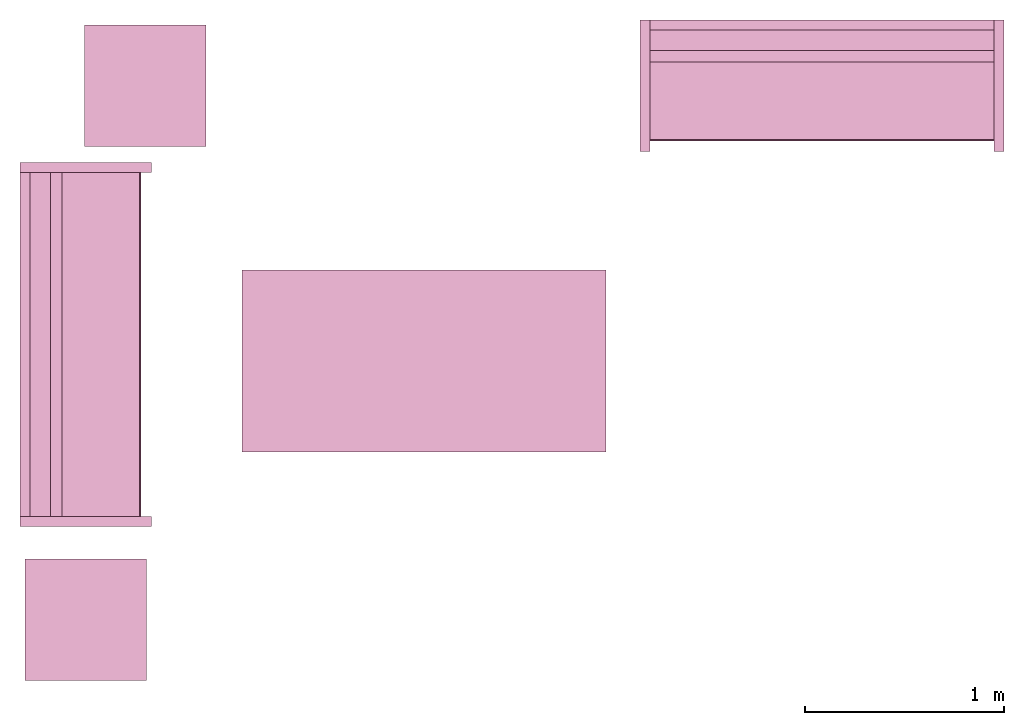
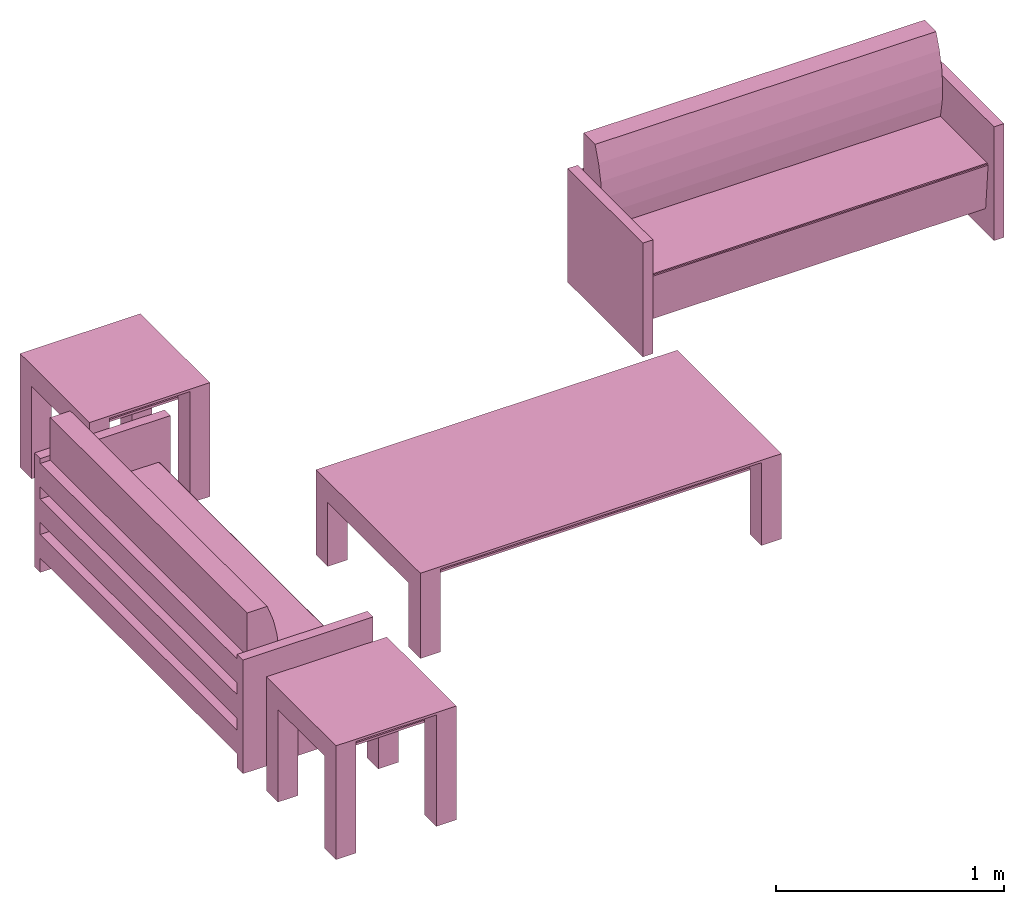
# One storey: 5 furnishings.
"""IFC2X3 building model written with IfcOpenShell, lengths in metres."""

from ifc_helpers import new_model, entity, si_unit, converted_unit, frame, origin, origin_with_axes, origin_2d_with_axis, place, context, project, spatial, polyline, rectangle, outline, extrude, face_set, surface_model, source, transform, mapped, type_object, type_shapes, element, save


model = new_model("IFC2X3")

# Units and contexts
model_context = context("Model", 3, precision=1e-09, world=origin())
plan_context = context("Plan", 3, precision=1e-09, world=origin())
ifc_project = project(units=[si_unit("LENGTHUNIT", "METRE"), si_unit("AREAUNIT", "SQUARE_METRE"), si_unit("VOLUMEUNIT", "CUBIC_METRE"), converted_unit("PLANEANGLEUNIT", "DEGREE", entity("IfcRatioMeasure", 0.0174532925199433), si_unit("PLANEANGLEUNIT", "RADIAN"), dimensions=[0, 0, 0, 0, 0, 0, 0]), si_unit("TIMEUNIT", "SECOND")], contexts=[model_context, plan_context])

# Site, building, storey, space
site_placement = place(None, origin_with_axes())
site = spatial("IfcSite", under=ifc_project, at=site_placement, CompositionType="ELEMENT")
building_placement = place(None, origin_with_axes())
building = spatial("IfcBuilding", under=site, at=building_placement, CompositionType="ELEMENT")
storey_placement = place(None, origin_with_axes())
storey = spatial("IfcBuildingStorey", under=building, at=storey_placement, Name="Level 1", CompositionType="ELEMENT", Elevation=0.0)
space_placement = place(None, origin_with_axes())
space = spatial("IfcSpace", under=storey, at=space_placement, CompositionType="ELEMENT", InteriorOrExteriorSpace="INTERNAL")

# Furnishings
furniture_type_1 = type_object("IfcFurnitureType", Name="0915 x 1830 x 0457mm", AssemblyPlace="NOTDEFINED")
shared_shape_1 = source(origin(), model_context, "Body", "SweptSolid", [
    extrude(rectangle(XDim=1.6268, YDim=0.711799999999999, at=origin_2d_with_axis()), frame((0.0182657666726317, 0.0952110778022268, 0.3427), z_axis=(0.0, 0.0, 1.0), x_axis=(-1.0, 0.0, 0.0)), (0.0, 0.0, 1.0), 0.0127),
    extrude(outline(polyline([(-0.196749999999994, -0.4575), (0.247549999999978, -0.4575), (0.247549999999978, 0.457499999999999), (-0.196749999999993, 0.457499999999999), (-0.196749999999993, 0.355900000000002), (0.145950000000009, 0.355900000000001), (0.145950000000009, -0.3559), (-0.196749999999994, -0.3559), (-0.196749999999994, -0.4575)])), frame((0.831665766672632, 0.0952110778022354, 0.196749999999991), z_axis=(1.0, 0.0, 0.0), x_axis=(0.0, 0.0, 1.0)), (0.0, 0.0, 1.0), 0.1016),
    extrude(outline(polyline([(-0.457500000000004, -0.247550000000026), (0.457499999999994, -0.247550000000026), (0.457499999999994, 0.196750000000011), (0.355900000000004, 0.196750000000011), (0.355900000000004, -0.145949999999996), (-0.355899999999994, -0.145949999999996), (-0.355899999999994, 0.196750000000011), (-0.457500000000004, 0.196750000000011), (-0.457500000000004, -0.247550000000026)])), frame((-0.896734233327367, 0.0952110778022256, 0.196750000000009), z_axis=(1.0, 0.0, 0.0), x_axis=(0.0, -1.0, 0.0)), (0.0, 0.0, 1.0), 0.1016),
    extrude(rectangle(XDim=1.6268, YDim=0.711799999999999, at=origin_2d_with_axis()), frame((0.0182657666726317, 0.0952110778022265, 0.4443), z_axis=(0.0, 0.0, 1.0), x_axis=(-1.0, 0.0, 0.0)), (0.0, 0.0, 1.0), 0.0127),
    extrude(outline(polyline([(-0.915, -0.457500000000023), (0.915, -0.457500000000023), (0.915, 0.457500000000023), (-0.915, 0.457500000000023), (-0.915, -0.457500000000023)]), holes=[polyline([(-0.813399999999998, -0.355899999999975), (-0.813399999999998, 0.355900000000025), (0.813400000000001, 0.355900000000024), (0.813400000000001, -0.355899999999975), (-0.813399999999998, -0.355899999999975)])]), frame((0.0182657666726332, 0.0952110778022514, 0.4443), z_axis=(0.0, 0.0, 1.0), x_axis=(-1.0, 0.0, 0.0)), (0.0, 0.0, 1.0), 0.0127),
])
type_shapes(furniture_type_1, [shared_shape_1])
furnishing_1_placement = place(None, frame((2.61916508073939, -15.3431715869351, 0.0), z_axis=(0.0, 0.0, 1.0), x_axis=(-1.0, 0.0, 0.0)))
element("IfcFurnishingElement", 1, at=furnishing_1_placement, inside=space, type_object=furniture_type_1, Name="M_Table-Coffee:0915 x 1830 x 0457mm:0915 x 1830 x 0457mm", context=model_context, shape_type="MappedRepresentation", body=[
    mapped(shared_shape_1, transform((0.0, 0.0, 0.0), scale=1.0)),
])
furniture_type_2 = type_object("IfcFurnitureType", Name="1830mm", AssemblyPlace="NOTDEFINED")
shared_shape_2 = source(origin(), model_context, "Body", "SurfaceModel", [
    surface_model("IfcFaceBasedSurfaceModel", [(0.0507999999999982, 0.609599999999997, 0.5842), (0.0507999999999983, 0.660399999999998, 0.5842), (0.0507999999999983, 0.660399999999998, 0.4572), (0.0507999999999982, 0.609599999999997, 0.4572), (0.0507999999999982, 0.609599999999998, 0.3937), (0.0507999999999983, 0.660399999999998, 0.3937), (0.0507999999999983, 0.660399999999998, 0.2667), (0.0507999999999982, 0.609599999999998, 0.2667), (0.0507999999999982, 0.609600000000004, 0.2032), (0.0507999999999983, 0.660399999999998, 0.2032), (0.0507999999999983, 0.660399999999998, 0.0762), (0.0507999999999982, 0.609600000000004, 0.0762), (1.77919999999999, 0.609599999999994, 0.5842), (1.77919999999999, 0.609599999999994, 0.4572), (1.77919999999999, 0.660399999999995, 0.4572), (1.77919999999999, 0.660399999999995, 0.5842), (1.77919999999999, 0.609599999999995, 0.3937), (1.77919999999999, 0.609599999999995, 0.2667), (1.77919999999999, 0.660399999999995, 0.2667), (1.77919999999999, 0.660399999999995, 0.3937), (1.77919999999999, 0.609600000000001, 0.2032), (1.77919999999999, 0.609600000000001, 0.0762), (1.77919999999999, 0.660399999999995, 0.0762), (1.77919999999999, 0.660399999999995, 0.2032), (0.0507999999999978, 0.470222395089521, 0.380999999999998), (0.0507999999999978, 0.454401348887885, 0.467831162756508), (0.0507999999999978, 0.450300415835913, 0.555996567971167), (0.0507999999999978, 0.457992845249543, 0.643921438504357), (0.0507999999999978, 0.477341237862486, 0.730035293556011), (0.0507999999999979, 0.507999999999975, 0.812799999999995), (0.0507999999999981, 0.609599999999998, 0.812799999999998), (0.0507999999999981, 0.609599999999998, 0.127966546684697), (0.0507999999999971, 0.0729375586579064, 0.127966546684697), (0.0507999999999971, 0.0520079452978146, 0.367193122067106), (0.0507999999999971, 0.0526336053189921, 0.372382281209352), (0.0507999999999971, 0.0552961957860913, 0.37687999563672), (0.0507999999999971, 0.0595447350023739, 0.379924455784818), (0.0507999999999971, 0.0646596179635799, 0.381000000000001), (1.77919999999998, 0.470222395089517, 0.381000000000001), (1.77919999999998, 0.0646596179635769, 0.381000000000001), (1.77919999999998, 0.059544735002371, 0.379924455784818), (1.77919999999998, 0.0552961957860883, 0.37687999563672), (1.77919999999998, 0.0526336053189891, 0.372382281209352), (1.77919999999998, 0.0520079452978117, 0.367193122067106), (1.77919999999998, 0.0729375586579034, 0.127966546684697), (1.77919999999998, 0.609599999999995, 0.127966546684697), (1.77919999999998, 0.609599999999995, 0.812799999999998), (1.77919999999998, 0.507999999999972, 0.812799999999995), (1.77919999999998, 0.477341237862483, 0.730035293556011), (1.77919999999998, 0.45799284524954, 0.643921438504357), (1.77919999999998, 0.45030041583591, 0.555996567971167), (1.77919999999998, 0.454401348887882, 0.467831162756508), (0.050799984484911, 0.0539648979902268, 0.374631136655807), (1.77919995784759, 0.0539648979902268, 0.374631136655807), (0.050799984484911, 0.0523207746446133, 0.369787722826004), (1.77919995784759, 0.0523207746446133, 0.369787722826004), (1.77919995784759, 0.0621021725237369, 0.380462229251862), (0.050799984484911, 0.0621788389980793, 0.380478352308273), (1.77919995784759, 0.0574204623699188, 0.378402233123779), (0.050799984484911, 0.0574204623699188, 0.378402233123779), (0.0507999999999971, 0.660399999999997, 0.6096), (0.0507999999999971, 0.0, 0.6096), (0.0, 0.0, 0.6096), (0.0, 0.660399999999997, 0.6096), (1.83, 0.660400000000039, 0.6096), (1.83, 0.0, 0.6096), (1.77919999999997, 0.0, 0.6096), (1.77919999999997, 0.660400000000039, 0.6096), (0.0507999999999971, 0.660399999999997, 0.0), (0.0507999999999971, 0.0, 0.0), (0.0, 0.0, 0.0), (0.0, 0.660399999999997, 0.0), (1.83, 0.660400000000039, 0.0), (1.83, 0.0, 0.0), (1.77919999999997, 0.0, 0.0), (1.77919999999997, 0.660400000000039, 0.0)], [face_set([[[0, 1, 2, 3]], [[4, 5, 6, 7]], [[8, 9, 10, 11]], [[12, 13, 14, 15]], [[16, 17, 18, 19]], [[20, 21, 22, 23]], [[1, 15, 12, 0]], [[2, 14, 15, 1]], [[3, 2, 14, 13]], [[0, 3, 13, 12]], [[5, 19, 16, 4]], [[6, 18, 19, 5]], [[7, 6, 18, 17]], [[4, 7, 17, 16]], [[9, 23, 20, 8]], [[10, 22, 23, 9]], [[11, 10, 22, 21]], [[8, 11, 21, 20]]]), face_set([[[24, 25, 26, 27, 28, 29, 30, 31, 32, 33, 34, 35, 36, 37]], [[38, 39, 40, 41, 42, 43, 44, 45, 46, 47, 48, 49, 50, 51]], [[24, 25, 51, 38]], [[25, 26, 50, 51]], [[49, 50, 26, 27]], [[27, 28, 48, 49]], [[28, 29, 47, 48]], [[30, 46, 47, 29]], [[31, 30, 46, 45]], [[32, 31, 45, 44]], [[33, 32, 44, 43]], [[41, 35, 52, 53]], [[54, 55, 42, 34]], [[33, 43, 55, 54]], [[34, 42, 53, 52]], [[39, 56, 57]], [[35, 41, 58, 59]], [[56, 40, 36]], [[57, 37, 39]], [[57, 56, 36]], [[40, 36, 59, 58]], [[24, 38, 39, 37]]]), face_set([[[60, 61, 62, 63]], [[64, 65, 66, 67]], [[68, 69, 70, 71]], [[72, 73, 74, 75]], [[63, 60, 68, 71]], [[62, 63, 71, 70]], [[61, 62, 70, 69]], [[60, 68, 69, 61]], [[67, 64, 72, 75]], [[66, 74, 75, 67]], [[65, 66, 74, 73]], [[64, 65, 73, 72]]])]),
])
type_shapes(furniture_type_2, [shared_shape_2])
furnishing_2_placement = place(None, frame((1.23109931406676, -16.2703826647373, 0.0), z_axis=(0.0, 0.0, 1.0), x_axis=(0.0, 1.0, 0.0)))
element("IfcFurnishingElement", 2, at=furnishing_2_placement, inside=space, type_object=furniture_type_2, Name="M_Sofa:1830mm:1830mm", context=model_context, shape_type="MappedRepresentation", body=[
    mapped(shared_shape_2, transform((0.0, 0.0, 0.0), scale=1.0)),
])
furnishing_3_placement = place(space_placement, frame((3.68589931406676, -14.3855826647373, 0.0), z_axis=(0.0, 0.0, 1.0), x_axis=(1.0, 0.0, 0.0)))
element("IfcFurnishingElement", 3, at=furnishing_3_placement, inside=space, type_object=furniture_type_2, Name="M_Sofa:1830mm:1830mm", context=model_context, shape_type="MappedRepresentation", body=[
    mapped(shared_shape_2, transform((0.0, 0.0, 0.0), scale=1.0)),
])
furniture_type_3 = type_object("IfcFurnitureType", Name="0610 x 0610 x 0610mm", AssemblyPlace="NOTDEFINED")
shared_shape_3 = source(origin(), model_context, "Body", "SweptSolid", [
    extrude(rectangle(XDim=0.406799999999999, YDim=0.406799999999999, at=origin_2d_with_axis()), frame((0.0182657666726316, 0.0952110778022263, 0.4957), z_axis=(0.0, 0.0, 1.0), x_axis=(-1.0, 0.0, 0.0)), (0.0, 0.0, 1.0), 0.0127),
    extrude(outline(polyline([(-0.273249999999994, -0.305), (0.324049999999978, -0.305), (0.324049999999978, 0.304999999999998), (-0.273249999999993, 0.304999999999999), (-0.273249999999993, 0.203400000000001), (0.222450000000009, 0.203400000000001), (0.222450000000009, -0.2034), (-0.273249999999994, -0.2034), (-0.273249999999994, -0.305)])), frame((0.221665766672633, 0.0952110778022354, 0.273249999999992), z_axis=(1.0, 0.0, 0.0), x_axis=(0.0, 0.0, 1.0)), (0.0, 0.0, 1.0), 0.1016),
    extrude(outline(polyline([(-0.305000000000004, -0.324050000000025), (0.304999999999994, -0.324050000000025), (0.304999999999994, 0.273250000000011), (0.203400000000004, 0.273250000000011), (0.203400000000004, -0.222449999999996), (-0.203399999999995, -0.222449999999996), (-0.203399999999995, 0.273250000000011), (-0.305000000000004, 0.273250000000011), (-0.305000000000004, -0.324050000000025)])), frame((-0.286734233327367, 0.0952110778022256, 0.273250000000008), z_axis=(1.0, 0.0, 0.0), x_axis=(0.0, -1.0, 0.0)), (0.0, 0.0, 1.0), 0.1016),
    extrude(rectangle(XDim=0.406799999999999, YDim=0.406799999999999, at=origin_2d_with_axis()), frame((0.0182657666726316, 0.0952110778022259, 0.5973), z_axis=(0.0, 0.0, 1.0), x_axis=(-1.0, 0.0, 0.0)), (0.0, 0.0, 1.0), 0.0127),
    extrude(outline(polyline([(-0.305, -0.305000000000023), (0.305, -0.305000000000023), (0.305, 0.305000000000023), (-0.305, 0.305000000000023), (-0.305, -0.305000000000023)]), holes=[polyline([(-0.203399999999998, -0.203399999999975), (-0.203399999999998, 0.203400000000025), (0.203400000000001, 0.203400000000025), (0.203400000000001, -0.203399999999975), (-0.203399999999998, -0.203399999999975)])]), frame((0.0182657666726332, 0.0952110778022508, 0.5973), z_axis=(0.0, 0.0, 1.0), x_axis=(-1.0, 0.0, 0.0)), (0.0, 0.0, 1.0), 0.0127),
])
type_shapes(furniture_type_3, [shared_shape_3])
for number, where, z_axis, x_axis, name in (
    (4, (1.21916508073938, -13.9601715869351, 0.0), (0.0, 0.0, 1.0), (-1.0, 0.0, 0.0), "M_Table-Coffee:0610 x 0610 x 0610mm:0610 x 0610 x 0610mm"),
    (5, (0.919165080739398, -16.6431715869351, 0.0), (0.0, 0.0, 1.0), (-1.0, 0.0, 0.0), "M_Table-Coffee:0610 x 0610 x 0610mm:0610 x 0610 x 0610mm"),
):
    element("IfcFurnishingElement", number, at=place(None, frame(where, z_axis=z_axis, x_axis=x_axis)), inside=space, type_object=furniture_type_3, Name=name, context=model_context, shape_type="MappedRepresentation", body=[
        mapped(shared_shape_3, transform((0.0, 0.0, 0.0), scale=1.0)),
    ])

save(model, "model.ifc")
